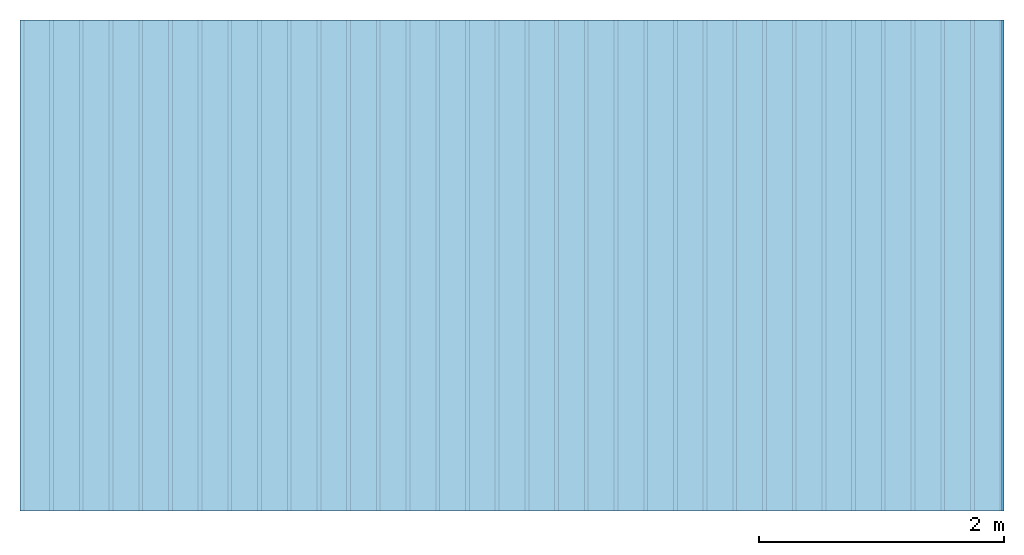
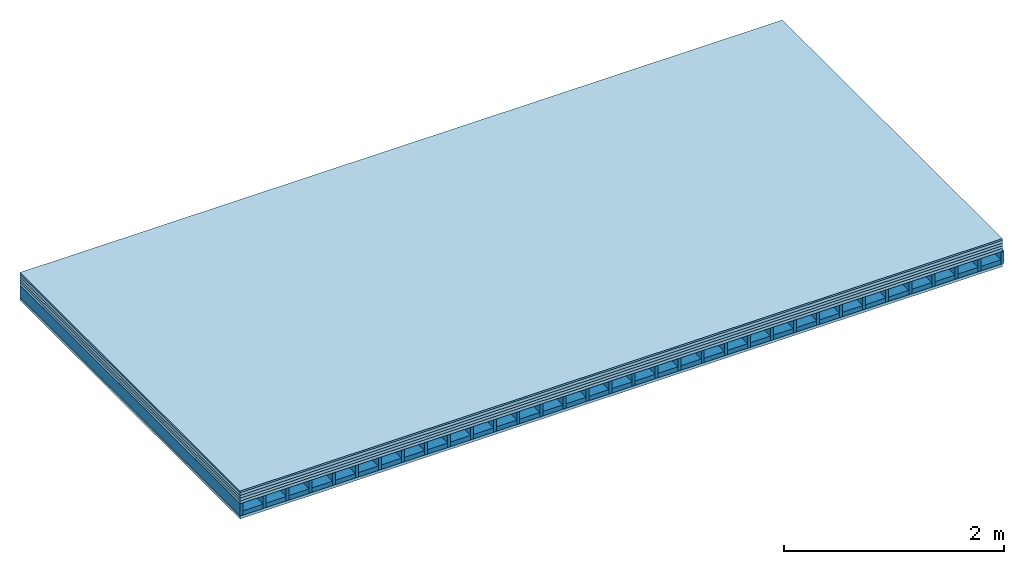
# One storey: 6 plates, 2 members, 1 element without a shape of its own.
"""IFC4 building model written with IfcOpenShell, lengths in metres."""

from ifc_helpers import new_model, si_unit, derived_unit, direction, frame, frame_2d, origin, origin_with_axes, place, context, project, spatial, rectangle, extrude, material, layer, layer_set, type_object, element, aggregate, save


model = new_model("IFC4")

# Units and contexts
plan_context = context("Plan", 3, precision=1e-05, world=origin(), true_north=direction((0.0, 1.0)))
model_context = context("Model", 3, precision=1e-05, world=origin(), true_north=direction((0.0, 1.0)))
ifc_project = project(units=[si_unit("LENGTHUNIT", "METRE"), derived_unit("SOUNDPRESSUREUNIT", [(si_unit("PRESSUREUNIT", "PASCAL", prefix="MICRO"), 0)]), si_unit("ENERGYUNIT", "JOULE", prefix="MEGA"), si_unit("MASSUNIT", "GRAM", prefix="KILO"), derived_unit("THERMALTRANSMITTANCEUNIT", [(si_unit("POWERUNIT", "WATT"), 1), (si_unit("AREAUNIT", "SQUARE_METRE"), -1), (si_unit("THERMODYNAMICTEMPERATUREUNIT", "KELVIN"), -1)]), derived_unit("AREADENSITYUNIT", [(si_unit("MASSUNIT", "GRAM", prefix="KILO"), 1), (si_unit("AREAUNIT", "SQUARE_METRE"), -1)]), derived_unit("USERDEFINED", [(si_unit("ENERGYUNIT", "JOULE", prefix="MEGA"), 1), (si_unit("AREAUNIT", "SQUARE_METRE"), -1)])], contexts=[plan_context, model_context])

# Site, building, storey
site = spatial("IfcSite", under=ifc_project)
building_placement = place(None, origin())
building = spatial("IfcBuilding", under=site, at=building_placement)
storey_placement = place(building_placement, origin())
storey = spatial("IfcBuildingStorey", under=building, at=storey_placement)

# Slab, members, plates
ifc_material_1 = material(Category="03.007")
ifc_layer_1 = layer(ifc_material_1, 0.018, Name="Flooring")
ifc_layer_2 = layer(ifc_material_1, 0.032, Name="On-material")
ifc_material_2 = material(Name="Impact sound insulation board TPT 03", Category="10.001")
ifc_layer_3 = layer(ifc_material_2, 0.03, Name="Impact sound insulation")
ifc_material_3 = material(Category="03.011")
ifc_layer_4 = layer(ifc_material_3, 0.03, Name="on Supporting structure")
ifc_material_4 = material(Name="surface element sheathing above")
ifc_layer_5 = layer(ifc_material_4, 0.031, Name="Sub-floor")
ifc_layer_6 = layer(None, 0.138, Name="Supporting structure")
ifc_material_5 = material(Name="surface element sheathing below")
ifc_layer_7 = layer(ifc_material_5, 0.031, Name="Lower layer 1")
ifc_layer_set = layer_set([ifc_layer_1, ifc_layer_2, ifc_layer_3, ifc_layer_4, ifc_layer_5, ifc_layer_6, ifc_layer_7])
slab_type = type_object("IfcSlabType", Name="A2699", PredefinedType="NOTDEFINED", material=ifc_layer_set)
slab_placement = place(None, frame((0.0, 0.0, 0.0), z_axis=(0.0, 0.0, -1.0), x_axis=(1.0, 0.0, 0.0)))
slab = element("IfcSlab", 1, at=slab_placement, inside=storey, type_object=slab_type, material=ifc_layer_set, Name="Slab #1")
ifc_material_6 = material(Name="surface element LFE")
member_1_placement = place(slab_placement, origin())
member_1 = element("IfcMember", 2, at=member_1_placement, material=ifc_material_6, Name="Supporting structure", context=plan_context, shape_type="SweptSolid", body=[
    extrude(rectangle(XDim=0.031, YDim=0.138, at=frame_2d((0.0155, 0.069), x_axis=(1.0, 0.0))), frame((0.0, 4.0, 0.141), z_axis=(0.0, -1.0, 0.0), x_axis=(1.0, 0.0, 0.0)), (0.0, 0.0, 1.0), 4.0),
    extrude(rectangle(XDim=0.031, YDim=0.138, at=frame_2d((0.0155, 0.069), x_axis=(1.0, 0.0))), frame((0.242, 4.0, 0.141), z_axis=(0.0, -1.0, 0.0), x_axis=(1.0, 0.0, 0.0)), (0.0, 0.0, 1.0), 4.0),
    extrude(rectangle(XDim=0.031, YDim=0.138, at=frame_2d((0.0155, 0.069), x_axis=(1.0, 0.0))), frame((0.484, 4.0, 0.141), z_axis=(0.0, -1.0, 0.0), x_axis=(1.0, 0.0, 0.0)), (0.0, 0.0, 1.0), 4.0),
    extrude(rectangle(XDim=0.031, YDim=0.138, at=frame_2d((0.0155, 0.069), x_axis=(1.0, 0.0))), frame((0.726, 4.0, 0.141), z_axis=(0.0, -1.0, 0.0), x_axis=(1.0, 0.0, 0.0)), (0.0, 0.0, 1.0), 4.0),
    extrude(rectangle(XDim=0.031, YDim=0.138, at=frame_2d((0.0155, 0.069), x_axis=(1.0, 0.0))), frame((0.968, 4.0, 0.141), z_axis=(0.0, -1.0, 0.0), x_axis=(1.0, 0.0, 0.0)), (0.0, 0.0, 1.0), 4.0),
    extrude(rectangle(XDim=0.031, YDim=0.138, at=frame_2d((0.0155, 0.069), x_axis=(1.0, 0.0))), frame((1.21, 4.0, 0.141), z_axis=(0.0, -1.0, 0.0), x_axis=(1.0, 0.0, 0.0)), (0.0, 0.0, 1.0), 4.0),
    extrude(rectangle(XDim=0.031, YDim=0.138, at=frame_2d((0.0155, 0.069), x_axis=(1.0, 0.0))), frame((1.452, 4.0, 0.141), z_axis=(0.0, -1.0, 0.0), x_axis=(1.0, 0.0, 0.0)), (0.0, 0.0, 1.0), 4.0),
    extrude(rectangle(XDim=0.031, YDim=0.138, at=frame_2d((0.0155, 0.069), x_axis=(1.0, 0.0))), frame((1.694, 4.0, 0.141), z_axis=(0.0, -1.0, 0.0), x_axis=(1.0, 0.0, 0.0)), (0.0, 0.0, 1.0), 4.0),
    extrude(rectangle(XDim=0.031, YDim=0.138, at=frame_2d((0.0155, 0.069), x_axis=(1.0, 0.0))), frame((1.936, 4.0, 0.141), z_axis=(0.0, -1.0, 0.0), x_axis=(1.0, 0.0, 0.0)), (0.0, 0.0, 1.0), 4.0),
    extrude(rectangle(XDim=0.031, YDim=0.138, at=frame_2d((0.0155, 0.069), x_axis=(1.0, 0.0))), frame((2.178, 4.0, 0.141), z_axis=(0.0, -1.0, 0.0), x_axis=(1.0, 0.0, 0.0)), (0.0, 0.0, 1.0), 4.0),
    extrude(rectangle(XDim=0.031, YDim=0.138, at=frame_2d((0.0155, 0.069), x_axis=(1.0, 0.0))), frame((2.42, 4.0, 0.141), z_axis=(0.0, -1.0, 0.0), x_axis=(1.0, 0.0, 0.0)), (0.0, 0.0, 1.0), 4.0),
    extrude(rectangle(XDim=0.031, YDim=0.138, at=frame_2d((0.0155, 0.069), x_axis=(1.0, 0.0))), frame((2.662, 4.0, 0.141), z_axis=(0.0, -1.0, 0.0), x_axis=(1.0, 0.0, 0.0)), (0.0, 0.0, 1.0), 4.0),
    extrude(rectangle(XDim=0.031, YDim=0.138, at=frame_2d((0.0155, 0.069), x_axis=(1.0, 0.0))), frame((2.904, 4.0, 0.141), z_axis=(0.0, -1.0, 0.0), x_axis=(1.0, 0.0, 0.0)), (0.0, 0.0, 1.0), 4.0),
    extrude(rectangle(XDim=0.031, YDim=0.138, at=frame_2d((0.0155, 0.069), x_axis=(1.0, 0.0))), frame((3.146, 4.0, 0.141), z_axis=(0.0, -1.0, 0.0), x_axis=(1.0, 0.0, 0.0)), (0.0, 0.0, 1.0), 4.0),
    extrude(rectangle(XDim=0.031, YDim=0.138, at=frame_2d((0.0155, 0.069), x_axis=(1.0, 0.0))), frame((3.388, 4.0, 0.141), z_axis=(0.0, -1.0, 0.0), x_axis=(1.0, 0.0, 0.0)), (0.0, 0.0, 1.0), 4.0),
    extrude(rectangle(XDim=0.031, YDim=0.138, at=frame_2d((0.0155, 0.069), x_axis=(1.0, 0.0))), frame((3.63, 4.0, 0.141), z_axis=(0.0, -1.0, 0.0), x_axis=(1.0, 0.0, 0.0)), (0.0, 0.0, 1.0), 4.0),
    extrude(rectangle(XDim=0.031, YDim=0.138, at=frame_2d((0.0155, 0.069), x_axis=(1.0, 0.0))), frame((3.872, 4.0, 0.141), z_axis=(0.0, -1.0, 0.0), x_axis=(1.0, 0.0, 0.0)), (0.0, 0.0, 1.0), 4.0),
    extrude(rectangle(XDim=0.031, YDim=0.138, at=frame_2d((0.0155, 0.069), x_axis=(1.0, 0.0))), frame((4.114, 4.0, 0.141), z_axis=(0.0, -1.0, 0.0), x_axis=(1.0, 0.0, 0.0)), (0.0, 0.0, 1.0), 4.0),
    extrude(rectangle(XDim=0.031, YDim=0.138, at=frame_2d((0.0155, 0.069), x_axis=(1.0, 0.0))), frame((4.356, 4.0, 0.141), z_axis=(0.0, -1.0, 0.0), x_axis=(1.0, 0.0, 0.0)), (0.0, 0.0, 1.0), 4.0),
    extrude(rectangle(XDim=0.031, YDim=0.138, at=frame_2d((0.0155, 0.069), x_axis=(1.0, 0.0))), frame((4.598, 4.0, 0.141), z_axis=(0.0, -1.0, 0.0), x_axis=(1.0, 0.0, 0.0)), (0.0, 0.0, 1.0), 4.0),
    extrude(rectangle(XDim=0.031, YDim=0.138, at=frame_2d((0.0155, 0.069), x_axis=(1.0, 0.0))), frame((4.84, 4.0, 0.141), z_axis=(0.0, -1.0, 0.0), x_axis=(1.0, 0.0, 0.0)), (0.0, 0.0, 1.0), 4.0),
    extrude(rectangle(XDim=0.031, YDim=0.138, at=frame_2d((0.0155, 0.069), x_axis=(1.0, 0.0))), frame((5.082, 4.0, 0.141), z_axis=(0.0, -1.0, 0.0), x_axis=(1.0, 0.0, 0.0)), (0.0, 0.0, 1.0), 4.0),
    extrude(rectangle(XDim=0.031, YDim=0.138, at=frame_2d((0.0155, 0.069), x_axis=(1.0, 0.0))), frame((5.324, 4.0, 0.141), z_axis=(0.0, -1.0, 0.0), x_axis=(1.0, 0.0, 0.0)), (0.0, 0.0, 1.0), 4.0),
    extrude(rectangle(XDim=0.031, YDim=0.138, at=frame_2d((0.0155, 0.069), x_axis=(1.0, 0.0))), frame((5.566, 4.0, 0.141), z_axis=(0.0, -1.0, 0.0), x_axis=(1.0, 0.0, 0.0)), (0.0, 0.0, 1.0), 4.0),
    extrude(rectangle(XDim=0.031, YDim=0.138, at=frame_2d((0.0155, 0.069), x_axis=(1.0, 0.0))), frame((5.808, 4.0, 0.141), z_axis=(0.0, -1.0, 0.0), x_axis=(1.0, 0.0, 0.0)), (0.0, 0.0, 1.0), 4.0),
    extrude(rectangle(XDim=0.031, YDim=0.138, at=frame_2d((0.0155, 0.069), x_axis=(1.0, 0.0))), frame((6.05, 4.0, 0.141), z_axis=(0.0, -1.0, 0.0), x_axis=(1.0, 0.0, 0.0)), (0.0, 0.0, 1.0), 4.0),
    extrude(rectangle(XDim=0.031, YDim=0.138, at=frame_2d((0.0155, 0.069), x_axis=(1.0, 0.0))), frame((6.292, 4.0, 0.141), z_axis=(0.0, -1.0, 0.0), x_axis=(1.0, 0.0, 0.0)), (0.0, 0.0, 1.0), 4.0),
    extrude(rectangle(XDim=0.031, YDim=0.138, at=frame_2d((0.0155, 0.069), x_axis=(1.0, 0.0))), frame((6.534, 4.0, 0.141), z_axis=(0.0, -1.0, 0.0), x_axis=(1.0, 0.0, 0.0)), (0.0, 0.0, 1.0), 4.0),
    extrude(rectangle(XDim=0.031, YDim=0.138, at=frame_2d((0.0155, 0.069), x_axis=(1.0, 0.0))), frame((6.776, 4.0, 0.141), z_axis=(0.0, -1.0, 0.0), x_axis=(1.0, 0.0, 0.0)), (0.0, 0.0, 1.0), 4.0),
    extrude(rectangle(XDim=0.031, YDim=0.138, at=frame_2d((0.0155, 0.069), x_axis=(1.0, 0.0))), frame((7.018, 4.0, 0.141), z_axis=(0.0, -1.0, 0.0), x_axis=(1.0, 0.0, 0.0)), (0.0, 0.0, 1.0), 4.0),
    extrude(rectangle(XDim=0.031, YDim=0.138, at=frame_2d((0.0155, 0.069), x_axis=(1.0, 0.0))), frame((7.26, 4.0, 0.141), z_axis=(0.0, -1.0, 0.0), x_axis=(1.0, 0.0, 0.0)), (0.0, 0.0, 1.0), 4.0),
    extrude(rectangle(XDim=0.031, YDim=0.138, at=frame_2d((0.0155, 0.069), x_axis=(1.0, 0.0))), frame((7.502, 4.0, 0.141), z_axis=(0.0, -1.0, 0.0), x_axis=(1.0, 0.0, 0.0)), (0.0, 0.0, 1.0), 4.0),
    extrude(rectangle(XDim=0.031, YDim=0.138, at=frame_2d((0.0155, 0.069), x_axis=(1.0, 0.0))), frame((7.744, 4.0, 0.141), z_axis=(0.0, -1.0, 0.0), x_axis=(1.0, 0.0, 0.0)), (0.0, 0.0, 1.0), 4.0),
    extrude(rectangle(XDim=0.031, YDim=0.138, at=frame_2d((0.0155, 0.069), x_axis=(1.0, 0.0))), frame((7.986, 4.0, 0.141), z_axis=(0.0, -1.0, 0.0), x_axis=(1.0, 0.0, 0.0)), (0.0, 0.0, 1.0), 4.0),
])
member_2_placement = place(slab_placement, origin())
member_2 = element("IfcMember", 3, at=member_2_placement, material=ifc_material_3, Name="in supporting structure", context=plan_context, shape_type="SweptSolid", body=[
    extrude(rectangle(XDim=0.211, YDim=0.049, at=frame_2d((0.1055, 0.0245), x_axis=(1.0, 0.0))), frame((0.031, 4.0, 0.23), z_axis=(0.0, -1.0, 0.0), x_axis=(1.0, 0.0, 0.0)), (0.0, 0.0, 1.0), 4.0),
    extrude(rectangle(XDim=0.211, YDim=0.049, at=frame_2d((0.1055, 0.0245), x_axis=(1.0, 0.0))), frame((0.273, 4.0, 0.23), z_axis=(0.0, -1.0, 0.0), x_axis=(1.0, 0.0, 0.0)), (0.0, 0.0, 1.0), 4.0),
    extrude(rectangle(XDim=0.211, YDim=0.049, at=frame_2d((0.1055, 0.0245), x_axis=(1.0, 0.0))), frame((0.515, 4.0, 0.23), z_axis=(0.0, -1.0, 0.0), x_axis=(1.0, 0.0, 0.0)), (0.0, 0.0, 1.0), 4.0),
    extrude(rectangle(XDim=0.211, YDim=0.049, at=frame_2d((0.1055, 0.0245), x_axis=(1.0, 0.0))), frame((0.757, 4.0, 0.23), z_axis=(0.0, -1.0, 0.0), x_axis=(1.0, 0.0, 0.0)), (0.0, 0.0, 1.0), 4.0),
    extrude(rectangle(XDim=0.211, YDim=0.049, at=frame_2d((0.1055, 0.0245), x_axis=(1.0, 0.0))), frame((0.999, 4.0, 0.23), z_axis=(0.0, -1.0, 0.0), x_axis=(1.0, 0.0, 0.0)), (0.0, 0.0, 1.0), 4.0),
    extrude(rectangle(XDim=0.211, YDim=0.049, at=frame_2d((0.1055, 0.0245), x_axis=(1.0, 0.0))), frame((1.241, 4.0, 0.23), z_axis=(0.0, -1.0, 0.0), x_axis=(1.0, 0.0, 0.0)), (0.0, 0.0, 1.0), 4.0),
    extrude(rectangle(XDim=0.211, YDim=0.049, at=frame_2d((0.1055, 0.0245), x_axis=(1.0, 0.0))), frame((1.483, 4.0, 0.23), z_axis=(0.0, -1.0, 0.0), x_axis=(1.0, 0.0, 0.0)), (0.0, 0.0, 1.0), 4.0),
    extrude(rectangle(XDim=0.211, YDim=0.049, at=frame_2d((0.1055, 0.0245), x_axis=(1.0, 0.0))), frame((1.725, 4.0, 0.23), z_axis=(0.0, -1.0, 0.0), x_axis=(1.0, 0.0, 0.0)), (0.0, 0.0, 1.0), 4.0),
    extrude(rectangle(XDim=0.211, YDim=0.049, at=frame_2d((0.1055, 0.0245), x_axis=(1.0, 0.0))), frame((1.967, 4.0, 0.23), z_axis=(0.0, -1.0, 0.0), x_axis=(1.0, 0.0, 0.0)), (0.0, 0.0, 1.0), 4.0),
    extrude(rectangle(XDim=0.211, YDim=0.049, at=frame_2d((0.1055, 0.0245), x_axis=(1.0, 0.0))), frame((2.209, 4.0, 0.23), z_axis=(0.0, -1.0, 0.0), x_axis=(1.0, 0.0, 0.0)), (0.0, 0.0, 1.0), 4.0),
    extrude(rectangle(XDim=0.211, YDim=0.049, at=frame_2d((0.1055, 0.0245), x_axis=(1.0, 0.0))), frame((2.451, 4.0, 0.23), z_axis=(0.0, -1.0, 0.0), x_axis=(1.0, 0.0, 0.0)), (0.0, 0.0, 1.0), 4.0),
    extrude(rectangle(XDim=0.211, YDim=0.049, at=frame_2d((0.1055, 0.0245), x_axis=(1.0, 0.0))), frame((2.693, 4.0, 0.23), z_axis=(0.0, -1.0, 0.0), x_axis=(1.0, 0.0, 0.0)), (0.0, 0.0, 1.0), 4.0),
    extrude(rectangle(XDim=0.211, YDim=0.049, at=frame_2d((0.1055, 0.0245), x_axis=(1.0, 0.0))), frame((2.935, 4.0, 0.23), z_axis=(0.0, -1.0, 0.0), x_axis=(1.0, 0.0, 0.0)), (0.0, 0.0, 1.0), 4.0),
    extrude(rectangle(XDim=0.211, YDim=0.049, at=frame_2d((0.1055, 0.0245), x_axis=(1.0, 0.0))), frame((3.177, 4.0, 0.23), z_axis=(0.0, -1.0, 0.0), x_axis=(1.0, 0.0, 0.0)), (0.0, 0.0, 1.0), 4.0),
    extrude(rectangle(XDim=0.211, YDim=0.049, at=frame_2d((0.1055, 0.0245), x_axis=(1.0, 0.0))), frame((3.419, 4.0, 0.23), z_axis=(0.0, -1.0, 0.0), x_axis=(1.0, 0.0, 0.0)), (0.0, 0.0, 1.0), 4.0),
    extrude(rectangle(XDim=0.211, YDim=0.049, at=frame_2d((0.1055, 0.0245), x_axis=(1.0, 0.0))), frame((3.661, 4.0, 0.23), z_axis=(0.0, -1.0, 0.0), x_axis=(1.0, 0.0, 0.0)), (0.0, 0.0, 1.0), 4.0),
    extrude(rectangle(XDim=0.211, YDim=0.049, at=frame_2d((0.1055, 0.0245), x_axis=(1.0, 0.0))), frame((3.903, 4.0, 0.23), z_axis=(0.0, -1.0, 0.0), x_axis=(1.0, 0.0, 0.0)), (0.0, 0.0, 1.0), 4.0),
    extrude(rectangle(XDim=0.211, YDim=0.049, at=frame_2d((0.1055, 0.0245), x_axis=(1.0, 0.0))), frame((4.145, 4.0, 0.23), z_axis=(0.0, -1.0, 0.0), x_axis=(1.0, 0.0, 0.0)), (0.0, 0.0, 1.0), 4.0),
    extrude(rectangle(XDim=0.211, YDim=0.049, at=frame_2d((0.1055, 0.0245), x_axis=(1.0, 0.0))), frame((4.387, 4.0, 0.23), z_axis=(0.0, -1.0, 0.0), x_axis=(1.0, 0.0, 0.0)), (0.0, 0.0, 1.0), 4.0),
    extrude(rectangle(XDim=0.211, YDim=0.049, at=frame_2d((0.1055, 0.0245), x_axis=(1.0, 0.0))), frame((4.629, 4.0, 0.23), z_axis=(0.0, -1.0, 0.0), x_axis=(1.0, 0.0, 0.0)), (0.0, 0.0, 1.0), 4.0),
    extrude(rectangle(XDim=0.211, YDim=0.049, at=frame_2d((0.1055, 0.0245), x_axis=(1.0, 0.0))), frame((4.871, 4.0, 0.23), z_axis=(0.0, -1.0, 0.0), x_axis=(1.0, 0.0, 0.0)), (0.0, 0.0, 1.0), 4.0),
    extrude(rectangle(XDim=0.211, YDim=0.049, at=frame_2d((0.1055, 0.0245), x_axis=(1.0, 0.0))), frame((5.113, 4.0, 0.23), z_axis=(0.0, -1.0, 0.0), x_axis=(1.0, 0.0, 0.0)), (0.0, 0.0, 1.0), 4.0),
    extrude(rectangle(XDim=0.211, YDim=0.049, at=frame_2d((0.1055, 0.0245), x_axis=(1.0, 0.0))), frame((5.355, 4.0, 0.23), z_axis=(0.0, -1.0, 0.0), x_axis=(1.0, 0.0, 0.0)), (0.0, 0.0, 1.0), 4.0),
    extrude(rectangle(XDim=0.211, YDim=0.049, at=frame_2d((0.1055, 0.0245), x_axis=(1.0, 0.0))), frame((5.597, 4.0, 0.23), z_axis=(0.0, -1.0, 0.0), x_axis=(1.0, 0.0, 0.0)), (0.0, 0.0, 1.0), 4.0),
    extrude(rectangle(XDim=0.211, YDim=0.049, at=frame_2d((0.1055, 0.0245), x_axis=(1.0, 0.0))), frame((5.839, 4.0, 0.23), z_axis=(0.0, -1.0, 0.0), x_axis=(1.0, 0.0, 0.0)), (0.0, 0.0, 1.0), 4.0),
    extrude(rectangle(XDim=0.211, YDim=0.049, at=frame_2d((0.1055, 0.0245), x_axis=(1.0, 0.0))), frame((6.081, 4.0, 0.23), z_axis=(0.0, -1.0, 0.0), x_axis=(1.0, 0.0, 0.0)), (0.0, 0.0, 1.0), 4.0),
    extrude(rectangle(XDim=0.211, YDim=0.049, at=frame_2d((0.1055, 0.0245), x_axis=(1.0, 0.0))), frame((6.323, 4.0, 0.23), z_axis=(0.0, -1.0, 0.0), x_axis=(1.0, 0.0, 0.0)), (0.0, 0.0, 1.0), 4.0),
    extrude(rectangle(XDim=0.211, YDim=0.049, at=frame_2d((0.1055, 0.0245), x_axis=(1.0, 0.0))), frame((6.565, 4.0, 0.23), z_axis=(0.0, -1.0, 0.0), x_axis=(1.0, 0.0, 0.0)), (0.0, 0.0, 1.0), 4.0),
    extrude(rectangle(XDim=0.211, YDim=0.049, at=frame_2d((0.1055, 0.0245), x_axis=(1.0, 0.0))), frame((6.807, 4.0, 0.23), z_axis=(0.0, -1.0, 0.0), x_axis=(1.0, 0.0, 0.0)), (0.0, 0.0, 1.0), 4.0),
    extrude(rectangle(XDim=0.211, YDim=0.049, at=frame_2d((0.1055, 0.0245), x_axis=(1.0, 0.0))), frame((7.049, 4.0, 0.23), z_axis=(0.0, -1.0, 0.0), x_axis=(1.0, 0.0, 0.0)), (0.0, 0.0, 1.0), 4.0),
    extrude(rectangle(XDim=0.211, YDim=0.049, at=frame_2d((0.1055, 0.0245), x_axis=(1.0, 0.0))), frame((7.291, 4.0, 0.23), z_axis=(0.0, -1.0, 0.0), x_axis=(1.0, 0.0, 0.0)), (0.0, 0.0, 1.0), 4.0),
    extrude(rectangle(XDim=0.211, YDim=0.049, at=frame_2d((0.1055, 0.0245), x_axis=(1.0, 0.0))), frame((7.533, 4.0, 0.23), z_axis=(0.0, -1.0, 0.0), x_axis=(1.0, 0.0, 0.0)), (0.0, 0.0, 1.0), 4.0),
    extrude(rectangle(XDim=0.211, YDim=0.049, at=frame_2d((0.1055, 0.0245), x_axis=(1.0, 0.0))), frame((7.775, 4.0, 0.23), z_axis=(0.0, -1.0, 0.0), x_axis=(1.0, 0.0, 0.0)), (0.0, 0.0, 1.0), 4.0),
])
plate_1_placement = place(slab_placement, origin())
plate_1 = element("IfcPlate", 4, at=plate_1_placement, material=ifc_material_1, Name="Flooring", context=plan_context, shape_type="SweptSolid", body=[
    extrude(rectangle(XDim=8.0, YDim=4.0, at=frame_2d((4.0, 2.0), x_axis=(1.0, 0.0))), origin_with_axes(), (0.0, 0.0, 1.0), 0.018),
])
plate_2_placement = place(slab_placement, origin())
plate_2 = element("IfcPlate", 5, at=plate_2_placement, material=ifc_material_1, Name="On-material", context=plan_context, shape_type="SweptSolid", body=[
    extrude(rectangle(XDim=8.0, YDim=4.0, at=frame_2d((4.0, 2.0), x_axis=(1.0, 0.0))), frame((0.0, 0.0, 0.018), z_axis=(0.0, 0.0, 1.0), x_axis=(1.0, 0.0, 0.0)), (0.0, 0.0, 1.0), 0.032),
])
plate_3_placement = place(slab_placement, origin())
plate_3 = element("IfcPlate", 6, at=plate_3_placement, material=ifc_material_2, Name="Impact sound insulation", context=plan_context, shape_type="SweptSolid", body=[
    extrude(rectangle(XDim=8.0, YDim=4.0, at=frame_2d((4.0, 2.0), x_axis=(1.0, 0.0))), frame((0.0, 0.0, 0.05), z_axis=(0.0, 0.0, 1.0), x_axis=(1.0, 0.0, 0.0)), (0.0, 0.0, 1.0), 0.03),
])
plate_4_placement = place(slab_placement, origin())
plate_4 = element("IfcPlate", 7, at=plate_4_placement, material=ifc_material_3, Name="on Supporting structure", context=plan_context, shape_type="SweptSolid", body=[
    extrude(rectangle(XDim=8.0, YDim=4.0, at=frame_2d((4.0, 2.0), x_axis=(1.0, 0.0))), frame((0.0, 0.0, 0.08), z_axis=(0.0, 0.0, 1.0), x_axis=(1.0, 0.0, 0.0)), (0.0, 0.0, 1.0), 0.03),
])
plate_5_placement = place(slab_placement, origin())
plate_5 = element("IfcPlate", 8, at=plate_5_placement, material=ifc_material_4, Name="Sub-floor", context=plan_context, shape_type="SweptSolid", body=[
    extrude(rectangle(XDim=8.0, YDim=4.0, at=frame_2d((4.0, 2.0), x_axis=(1.0, 0.0))), frame((0.0, 0.0, 0.11), z_axis=(0.0, 0.0, 1.0), x_axis=(1.0, 0.0, 0.0)), (0.0, 0.0, 1.0), 0.031),
])
plate_6_placement = place(slab_placement, origin())
plate_6 = element("IfcPlate", 9, at=plate_6_placement, material=ifc_material_5, Name="Lower layer 1", context=plan_context, shape_type="SweptSolid", body=[
    extrude(rectangle(XDim=8.0, YDim=4.0, at=frame_2d((4.0, 2.0), x_axis=(1.0, 0.0))), frame((0.0, 0.0, 0.279), z_axis=(0.0, 0.0, 1.0), x_axis=(1.0, 0.0, 0.0)), (0.0, 0.0, 1.0), 0.031),
])
aggregate(slab, [plate_1, plate_2, plate_3, plate_4, plate_5, member_1, member_2, plate_6])

save(model, "model.ifc")
